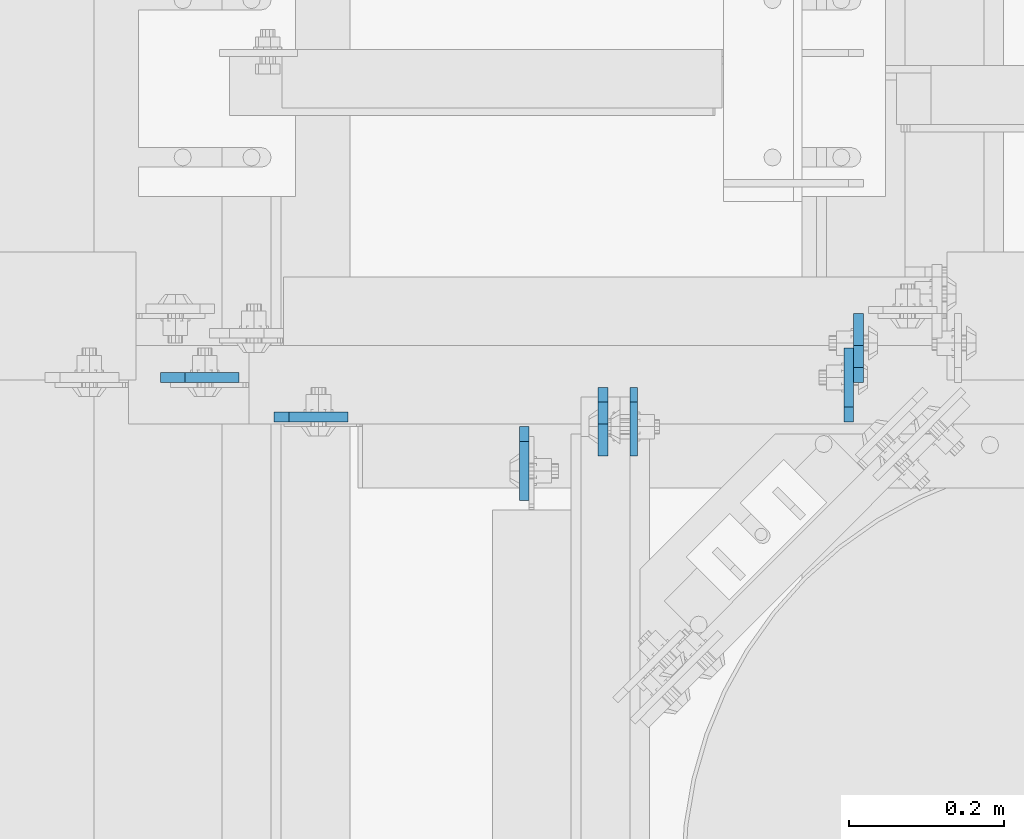
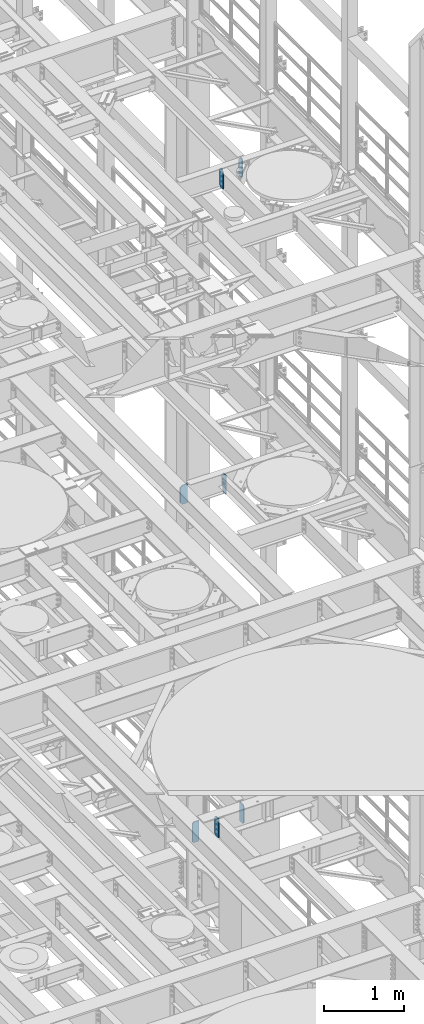
# One storey, part 1660 of 1876: 7 plates, 5 elements without a shape of their own.
"""IFC2X3 building model written with IfcOpenShell, lengths in millimetres."""

from ifc_helpers import new_model, si_unit, frame, origin_with_axes, place, context, subcontext, project, spatial, faceted_brep, material, type_object, element, aggregate, save


model = new_model("IFC2X3")

# Units and contexts
model_context = context("Model", 3, precision=1e-05, world=origin_with_axes())
body_context = subcontext(model_context, "Body", "Model", "MODEL_VIEW")
ifc_project = project(units=[si_unit("LENGTHUNIT", "METRE", prefix="MILLI"), si_unit("AREAUNIT", "SQUARE_METRE"), si_unit("VOLUMEUNIT", "CUBIC_METRE"), si_unit("MASSUNIT", "GRAM", prefix="KILO"), si_unit("TIMEUNIT", "SECOND"), si_unit("PLANEANGLEUNIT", "RADIAN"), si_unit("SOLIDANGLEUNIT", "STERADIAN"), si_unit("THERMODYNAMICTEMPERATUREUNIT", "DEGREE_CELSIUS"), si_unit("LUMINOUSINTENSITYUNIT", "LUMEN")], contexts=[model_context])

# Site, building, storey
site_placement = place(None, origin_with_axes())
site = spatial("IfcSite", under=ifc_project, at=site_placement, CompositionType="ELEMENT")
building_placement = place(site_placement, origin_with_axes())
building = spatial("IfcBuilding", under=site, at=building_placement, Name="Undefined", CompositionType="ELEMENT")
storey_placement = place(building_placement, origin_with_axes())
storey = spatial("IfcBuildingStorey", under=building, at=storey_placement, Name="Undefined", CompositionType="ELEMENT", Elevation=0.0)

# Assembly, plate
assembly_1_placement = place(storey_placement, origin_with_axes())
assembly_1 = element("IfcElementAssembly", 1, at=assembly_1_placement, inside=storey, Name="BEAM", AssemblyPlace="NOTDEFINED", PredefinedType="RIGID_FRAME")
ifc_material = material(Name="STEEL/A36")
plate_type_1 = type_object("IfcPlateType", PredefinedType="NOTDEFINED")
plate_1_placement = place(assembly_1_placement, frame((6265.86299991608, 4384.675, 13012.7375), z_axis=(0.0, 0.0, 1.0), x_axis=(0.0, -1.0, 0.0)))
plate_1 = element("IfcPlate", 2, at=plate_1_placement, type_object=plate_type_1, material=ifc_material, Name="PLATE", context=body_context, shape_type="Brep", body=[
    faceted_brep([(0.0, -4.76249999999982, 19.0499992370605), (0.0, -4.76249999999982, 271.462512969971), (0.0, 4.76249999999982, 271.462512969971), (0.0, 4.76249999999982, 19.0499992370605), (19.0499992370605, -4.76249999999982, 290.512512207031), (19.0499992370605, 4.76249999999982, 290.512512207031), (88.9000015258789, -4.76249999999982, 290.512512207031), (88.9000015258789, 4.76249999999982, 290.512512207031), (88.9000015258789, -4.76249999999982, 0.0), (88.9000015258789, 4.76249999999982, 0.0), (19.0499992370605, -4.76249999999982, 0.0), (19.0499992370605, 4.76249999999982, 0.0)], [[[0, 1, 2, 3]], [[1, 4, 5, 2]], [[4, 6, 7, 5]], [[6, 8, 9, 7]], [[8, 10, 11, 9]], [[10, 0, 3, 11]], [[5, 7, 9, 11, 3, 2]], [[10, 8, 6, 4, 1, 0]]]),
])
aggregate(assembly_1, [plate_1])

# Assembly, plates
assembly_2_placement = place(storey_placement, origin_with_axes())
assembly_2 = element("IfcElementAssembly", 3, at=assembly_2_placement, inside=storey, Name="BEAM", AssemblyPlace="NOTDEFINED", PredefinedType="RIGID_FRAME")
plate_type_2 = type_object("IfcPlateType", PredefinedType="NOTDEFINED")
plate_2_placement = place(assembly_2_placement, frame((6226.17499990463, 4384.675, 17686.3375), z_axis=(0.0, 0.0, 1.0), x_axis=(0.0, -1.0, 0.0)))
plate_2 = element("IfcPlate", 4, at=plate_2_placement, type_object=plate_type_2, material=ifc_material, Name="PLATE", context=body_context, shape_type="Brep", body=[
    faceted_brep([(0.0, -6.35000000000036, 271.462512969971), (19.0499992370605, -6.35000000000036, 290.512512207031), (19.0499992370605, 6.35000000000036, 290.512512207031), (0.0, 6.35000000000036, 271.462512969971), (0.0, -6.35000000000196, 19.0499992370605), (0.0, 6.35000000000105, 19.0499992370605), (19.0499992370642, -6.35000000000105, 0.0), (19.0499992370633, 6.35000000000105, 0.0), (88.9000015258789, -6.34999999999991, 0.0), (88.9000015258789, 6.34999999999991, 0.0), (88.9000015258789, -6.35000000000036, 249.237510681152), (47.625, -6.35000000000036, 290.512512207031), (47.625, 6.35000000000036, 290.512512207031), (88.9000015258789, 6.35000000000036, 249.237510681152)], [[[0, 1, 2, 3]], [[4, 0, 3, 5]], [[6, 4, 5, 7]], [[8, 6, 7, 9]], [[6, 8, 10, 11, 1, 0, 4]], [[1, 11, 12, 2]], [[2, 12, 13, 9, 7, 5, 3]], [[10, 8, 9, 13]], [[11, 10, 13, 12]]]),
])
plate_3_placement = place(assembly_2_placement, frame((6556.37500001859, 4391.025, 17686.3375), z_axis=(0.0, 0.0, 1.0), x_axis=(0.0, 1.0, 0.0)))
plate_3 = element("IfcPlate", 5, at=plate_3_placement, type_object=plate_type_2, material=ifc_material, Name="PLATE", context=body_context, shape_type="Brep", body=[
    faceted_brep([(0.0, -6.35000000000036, 271.462512969971), (19.0499992370605, -6.35000000000036, 290.512512207031), (19.0499992370605, 6.35000000000036, 290.512512207031), (0.0, 6.35000000000036, 271.462512969971), (0.0, -6.35000000000196, 19.0499992370605), (0.0, 6.35000000000105, 19.0499992370605), (19.0499992370642, -6.35000000000105, 0.0), (19.0499992370633, 6.35000000000105, 0.0), (88.9000015258789, -6.34999999999991, 0.0), (88.9000015258789, 6.34999999999991, 0.0), (88.9000015258789, -6.35000000000036, 249.237510681152), (47.625, -6.35000000000036, 290.512512207031), (47.625, 6.35000000000036, 290.512512207031), (88.9000015258789, 6.35000000000036, 249.237510681152)], [[[0, 1, 2, 3]], [[4, 0, 3, 5]], [[6, 4, 5, 7]], [[8, 6, 7, 9]], [[6, 8, 10, 11, 1, 0, 4]], [[1, 11, 12, 2]], [[2, 12, 13, 9, 7, 5, 3]], [[10, 8, 9, 13]], [[11, 10, 13, 12]]]),
])
aggregate(assembly_2, [plate_2, plate_3])

assembly_3_placement = place(storey_placement, origin_with_axes())
assembly_3 = element("IfcElementAssembly", 6, at=assembly_3_placement, inside=storey, Name="BEAM", AssemblyPlace="NOTDEFINED", PredefinedType="RIGID_FRAME")
plate_type_3 = type_object("IfcPlateType", PredefinedType="NOTDEFINED")
plate_4_placement = place(assembly_3_placement, frame((6124.57499990463, 4333.875, 7851.775), z_axis=(0.0, 0.0, 1.0), x_axis=(0.0, -1.0, 0.0)))
plate_4 = element("IfcPlate", 7, at=plate_4_placement, type_object=plate_type_3, material=ifc_material, Name="PLATE", context=body_context, shape_type="Brep", body=[
    faceted_brep([(0.0, -6.35000000000196, 19.0499992370605), (0.0, -6.35000000000036, 271.462512969971), (0.0, 6.35000000000036, 271.462512969971), (0.0, 6.35000000000105, 19.0499992370605), (19.0499992370605, -6.35000000000036, 290.512512207031), (19.0499992370605, 6.35000000000036, 290.512512207031), (95.25, -6.35000000000036, 290.512512207031), (95.25, 6.35000000000036, 290.512512207031), (95.25, -6.35000000000036, 0.0), (95.25, 6.35000000000036, 0.0), (19.0499992370642, -6.35000000000105, 0.0), (19.0499992370633, 6.35000000000105, 0.0)], [[[0, 1, 2, 3]], [[1, 4, 5, 2]], [[4, 6, 7, 5]], [[6, 8, 9, 7]], [[8, 10, 11, 9]], [[10, 0, 3, 11]], [[5, 7, 9, 11, 3, 2]], [[10, 8, 6, 4, 1, 0]]]),
])
plate_5_placement = place(assembly_3_placement, frame((6543.67499990463, 4340.225, 7851.775), z_axis=(0.0, 0.0, 1.0), x_axis=(0.0, 1.0, 0.0)))
plate_5 = element("IfcPlate", 8, at=plate_5_placement, type_object=plate_type_3, material=ifc_material, Name="PLATE", context=body_context, shape_type="Brep", body=[
    faceted_brep([(0.0, -6.35000000000196, 19.0499992370605), (0.0, -6.35000000000036, 271.462512969971), (0.0, 6.35000000000036, 271.462512969971), (0.0, 6.35000000000105, 19.0499992370605), (19.0499992370605, -6.35000000000036, 290.512512207031), (19.0499992370605, 6.35000000000036, 290.512512207031), (95.25, -6.35000000000036, 290.512512207031), (95.25, 6.35000000000036, 290.512512207031), (95.25, -6.35000000000036, 0.0), (95.25, 6.35000000000036, 0.0), (19.0499992370642, -6.35000000000105, 0.0), (19.0499992370633, 6.35000000000105, 0.0)], [[[0, 1, 2, 3]], [[1, 4, 5, 2]], [[4, 6, 7, 5]], [[6, 8, 9, 7]], [[8, 10, 11, 9]], [[10, 0, 3, 11]], [[5, 7, 9, 11, 3, 2]], [[10, 8, 6, 4, 1, 0]]]),
])
aggregate(assembly_3, [plate_4, plate_5])

# Assembly, plate
assembly_4_placement = place(storey_placement, origin_with_axes())
assembly_4 = element("IfcElementAssembly", 9, at=assembly_4_placement, inside=storey, Name="BEAM", AssemblyPlace="NOTDEFINED", PredefinedType="RIGID_FRAME")
plate_6_placement = place(assembly_4_placement, frame((5801.51875, 4346.57500009537, 7821.6125), z_axis=(0.0, 0.0, 1.0), x_axis=(1.0, 0.0, 0.0)))
plate_6 = element("IfcPlate", 10, at=plate_6_placement, type_object=plate_type_3, material=ifc_material, Name="PLATE", context=body_context, shape_type="Brep", body=[
    faceted_brep([(0.0, -6.35000000000196, 19.0499992370605), (-9.09494701772928e-13, -6.34999999999764, 296.862506866455), (1.81898940354586e-12, 6.34999999999786, 296.862506866455), (0.0, 6.35000000000105, 19.0499992370605), (19.0499992370587, -6.34999999999604, 315.912506103516), (19.0499992370624, 6.34999999999945, 315.912506103516), (95.25, -6.35000000000036, 315.912506103516), (95.25, 6.35000000000036, 315.912506103516), (95.25, -6.35000000000036, 0.0), (95.25, 6.35000000000036, 0.0), (19.0499992370642, -6.35000000000105, 0.0), (19.0499992370633, 6.35000000000105, 0.0)], [[[0, 1, 2, 3]], [[1, 4, 5, 2]], [[4, 6, 7, 5]], [[6, 8, 9, 7]], [[8, 10, 11, 9]], [[10, 0, 3, 11]], [[5, 7, 9, 11, 3, 2]], [[10, 8, 6, 4, 1, 0]]]),
])
aggregate(assembly_4, [plate_6])

assembly_5_placement = place(storey_placement, origin_with_axes())
assembly_5 = element("IfcElementAssembly", 11, at=assembly_5_placement, inside=storey, Name="BEAM", AssemblyPlace="NOTDEFINED", PredefinedType="RIGID_FRAME")
plate_type_4 = type_object("IfcPlateType", PredefinedType="NOTDEFINED")
plate_7_placement = place(assembly_5_placement, frame((5654.675, 4397.37500009537, 13007.975), z_axis=(0.0, 0.0, 1.0), x_axis=(1.0, 0.0, 0.0)))
plate_7 = element("IfcPlate", 12, at=plate_7_placement, type_object=plate_type_4, material=ifc_material, Name="PLATE", context=body_context, shape_type="Brep", body=[
    faceted_brep([(0.0, -6.34999999999991, 31.75), (0.0, -6.35000000000036, 258.762512207031), (0.0, 6.35000000000036, 258.762512207031), (0.0, 6.34999999999991, 31.75), (31.75, -6.35000000000036, 290.512512207031), (31.75, 6.35000000000036, 290.512512207031), (101.599998474121, -6.35000000000036, 290.512512207031), (101.599998474121, 6.35000000000036, 290.512512207031), (101.599998474121, -6.35000000000036, 0.0), (101.599998474121, 6.35000000000036, 0.0), (31.75, -6.34999999999991, 0.0), (31.75, 6.34999999999991, 0.0)], [[[0, 1, 2, 3]], [[1, 4, 5, 2]], [[4, 6, 7, 5]], [[6, 8, 9, 7]], [[8, 10, 11, 9]], [[10, 0, 3, 11]], [[5, 7, 9, 11, 3, 2]], [[10, 8, 6, 4, 1, 0]]]),
])
aggregate(assembly_5, [plate_7])

save(model, "model.ifc")
